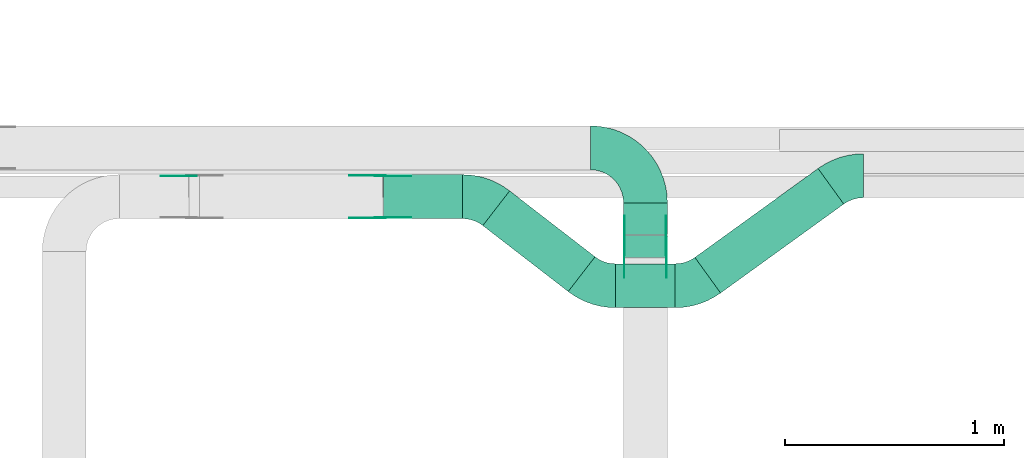
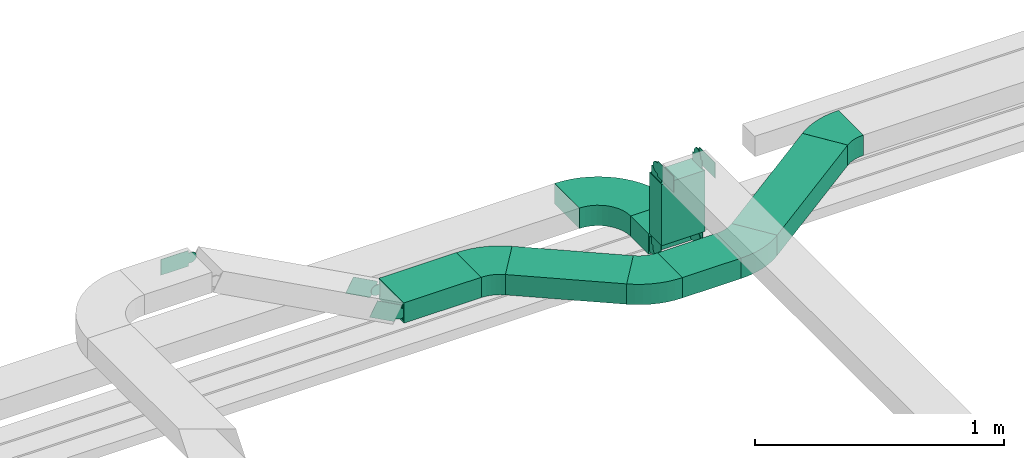
# One storey, part 5 of 25: 18 flow fittings, 6 flow segments.
"""IFC2X3 building model written with IfcOpenShell, lengths in millimetres."""

from ifc_helpers import new_model, entity, si_unit, converted_unit, derived_unit, direction, frame, frame_2d, origin, origin_2d_with_axis, place, context, subcontext, project, spatial, polyline, circle_curve, parameter, trimmed, segment, composite_curve, rectangle, outline, extrude, source, transform, mapped, material, type_object, type_shapes, element, save


model = new_model("IFC2X3")

# Units and contexts
model_context = context("Model", 3, precision=0.01, world=origin(), true_north=direction((6.12303176911189e-17, 1.0)))
body_context = subcontext(model_context, "Body", "Model", "MODEL_VIEW")
ifc_project = project(units=[si_unit("LENGTHUNIT", "METRE", prefix="MILLI"), si_unit("AREAUNIT", "SQUARE_METRE"), si_unit("VOLUMEUNIT", "CUBIC_METRE"), converted_unit("PLANEANGLEUNIT", "DEGREE", entity("IfcRatioMeasure", 0.0174532925199433), si_unit("PLANEANGLEUNIT", "RADIAN"), dimensions=[0, 0, 0, 0, 0, 0, 0]), si_unit("MASSUNIT", "GRAM", prefix="KILO"), derived_unit("MASSDENSITYUNIT", [(si_unit("MASSUNIT", "GRAM", prefix="KILO"), 1), (si_unit("LENGTHUNIT", "METRE"), -3)]), derived_unit("MOMENTOFINERTIAUNIT", [(si_unit("LENGTHUNIT", "METRE"), 4)]), si_unit("TIMEUNIT", "SECOND"), si_unit("FREQUENCYUNIT", "HERTZ"), si_unit("THERMODYNAMICTEMPERATUREUNIT", "DEGREE_CELSIUS"), derived_unit("THERMALTRANSMITTANCEUNIT", [(si_unit("MASSUNIT", "GRAM", prefix="KILO"), 1), (si_unit("THERMODYNAMICTEMPERATUREUNIT", "KELVIN"), -1), (si_unit("TIMEUNIT", "SECOND"), -3)]), derived_unit("VOLUMETRICFLOWRATEUNIT", [(si_unit("LENGTHUNIT", "METRE"), 3), (si_unit("TIMEUNIT", "SECOND"), -1)]), derived_unit("MASSFLOWRATEUNIT", [(si_unit("MASSUNIT", "GRAM", prefix="KILO"), 1), (si_unit("TIMEUNIT", "SECOND"), -1)]), derived_unit("ROTATIONALFREQUENCYUNIT", [(si_unit("TIMEUNIT", "SECOND"), -1)]), si_unit("ELECTRICCURRENTUNIT", "AMPERE"), si_unit("ELECTRICVOLTAGEUNIT", "VOLT"), si_unit("POWERUNIT", "WATT"), si_unit("FORCEUNIT", "NEWTON", prefix="KILO"), si_unit("ILLUMINANCEUNIT", "LUX"), si_unit("LUMINOUSFLUXUNIT", "LUMEN"), si_unit("LUMINOUSINTENSITYUNIT", "CANDELA"), derived_unit("USERDEFINED", [(si_unit("MASSUNIT", "GRAM", prefix="KILO"), -1), (si_unit("LENGTHUNIT", "METRE"), -2), (si_unit("TIMEUNIT", "SECOND"), 3), (si_unit("LUMINOUSFLUXUNIT", "LUMEN"), 1)]), derived_unit("LINEARVELOCITYUNIT", [(si_unit("LENGTHUNIT", "METRE"), 1), (si_unit("TIMEUNIT", "SECOND"), -1)]), si_unit("PRESSUREUNIT", "PASCAL"), derived_unit("USERDEFINED", [(si_unit("LENGTHUNIT", "METRE"), -2), (si_unit("MASSUNIT", "GRAM", prefix="KILO"), 1), (si_unit("TIMEUNIT", "SECOND"), -2)]), derived_unit("LINEARFORCEUNIT", [(si_unit("MASSUNIT", "GRAM", prefix="KILO"), 1), (si_unit("LENGTHUNIT", "METRE"), 1), (si_unit("TIMEUNIT", "SECOND"), -2), (si_unit("LENGTHUNIT", "METRE"), -1)]), derived_unit("PLANARFORCEUNIT", [(si_unit("MASSUNIT", "GRAM", prefix="KILO"), 1), (si_unit("LENGTHUNIT", "METRE"), 1), (si_unit("TIMEUNIT", "SECOND"), -2), (si_unit("LENGTHUNIT", "METRE"), -2)])], contexts=[model_context])

# Site, building, storey
site_placement = place(None, frame((0.0, -0.00077364408347762, 0.0)))
site = spatial("IfcSite", under=ifc_project, at=site_placement, CompositionType="ELEMENT")
building_placement = place(site_placement, origin())
building = spatial("IfcBuilding", under=site, at=building_placement, CompositionType="ELEMENT")
storey_placement = place(building_placement, frame((0.0, 0.0, 24000.0)))
storey = spatial("IfcBuildingStorey", under=building, at=storey_placement, CompositionType="ELEMENT", Elevation=24000.0)

# Flow segments
cable_carrier_segment_type = type_object("IfcCableCarrierSegmentType", PredefinedType="CABLETRAYSEGMENT")
flow_segment_1_placement = place(storey_placement, frame((22684.9807114228, 9729.94253623869, 2890.0)))
element("IfcFlowSegment", 1, at=flow_segment_1_placement, inside=storey, type_object=cable_carrier_segment_type, context=body_context, shape_type="SweptSolid", body=[
    extrude(rectangle(XDim=143.999999999998, YDim=199.999999999998, at=origin_2d_with_axis()), frame((100.0, 72.0, 0.0), z_axis=(0.0, 0.0, 1.0), x_axis=(0.0, -1.0, 0.0)), (0.0, 0.0, 1.0), 100.000000000003),
])
flow_segment_2_placement = place(storey_placement, frame((22684.9807114228, 9624.94253623869, 2995.0)))
element("IfcFlowSegment", 2, at=flow_segment_2_placement, inside=storey, type_object=cable_carrier_segment_type, context=body_context, shape_type="SweptSolid", body=[
    extrude(rectangle(XDim=199.999999999998, YDim=100.000000000001, at=origin_2d_with_axis()), frame((100.0, 50.0, 0.0)), (0.0, 0.0, 1.0), 299.999986293866),
])
flow_segment_3_placement = place(storey_placement, frame((21591.4331390634, 9802.6648899449, 2890.0)))
element("IfcFlowSegment", 3, at=flow_segment_3_placement, inside=storey, type_object=cable_carrier_segment_type, context=body_context, shape_type="SweptSolid", body=[
    extrude(rectangle(XDim=359.111266245777, YDim=199.999999999998, at=origin_2d_with_axis()), frame((179.555633122888, 100.0, 0.0), z_axis=(0.0, 0.0, 1.0), x_axis=(-1.0, 0.0, 0.0)), (0.0, 0.0, 1.0), 100.000000000003),
])
flow_segment_4_placement = place(storey_placement, frame((22648.7585625683, 9396.68870052396, 2890.0)))
element("IfcFlowSegment", 4, at=flow_segment_4_placement, inside=storey, type_object=cable_carrier_segment_type, context=body_context, shape_type="SweptSolid", body=[
    extrude(rectangle(XDim=271.84445040066, YDim=200.0, at=frame_2d((0.0, 5.47117906535277e-13), x_axis=(1.0, 0.0))), frame((135.92222520033, 100.0, 0.0)), (0.0, 0.0, 1.0), 100.000000000003),
])
flow_segment_5_placement = place(storey_placement, frame((22044.0293540784, 9470.30772844404, 2890.0)))
element("IfcFlowSegment", 5, at=flow_segment_5_placement, inside=storey, type_object=cable_carrier_segment_type, context=body_context, shape_type="SweptSolid", body=[
    extrude(rectangle(XDim=491.512542620555, YDim=200.000000000002, at=origin_2d_with_axis()), frame((255.622129860332, 229.369066790387, 0.0), z_axis=(0.0, 0.0, 1.0), x_axis=(-0.791406463891307, 0.611290282035514, 0.0)), (0.0, 0.0, 1.0), 100.000000000003),
])
flow_segment_6_placement = place(storey_placement, frame((23010.2445644588, 9463.54885381026, 2890.0)))
element("IfcFlowSegment", 6, at=flow_segment_6_placement, inside=storey, type_object=cable_carrier_segment_type, context=body_context, shape_type="SweptSolid", body=[
    extrude(rectangle(XDim=692.157993245641, YDim=200.0, at=frame_2d((-2.1032064978499e-12, 8.31335000839317e-13), x_axis=(1.0, 0.0))), frame((339.100786744327, 283.707278363112, 0.0), z_axis=(0.0, 0.0, 1.0), x_axis=(0.810643960277806, 0.585539383530361, 0.0)), (0.0, 0.0, 1.0), 100.000000000003),
])

# Flow fittings
ifc_material_1 = material(Name="G")
cable_carrier_fitting_type_1 = type_object("IfcCableCarrierFittingType", PredefinedType="NOTDEFINED", material=ifc_material_1)
shared_shape_1 = source(origin(), body_context, "Body", "SweptSolid", [
    extrude(outline(composite_curve([segment(trimmed(circle_curve(frame_2d((-41.4651162790697, 0.0), x_axis=(1.0, 0.0)), 25.0), [parameter(90.0000000000007)], [parameter(270.0)], True, "PARAMETER"), True, "CONTINUOUS"), segment(polyline([(-41.4651162790697, -25.0), (-29.9651162790697, -25.0)]), True, "CONTINUOUS"), segment(polyline([(-29.9651162790697, -25.0), (-28.1046511627907, -38.5)]), True, "CONTINUOUS"), segment(polyline([(-28.1046511627907, -38.5), (99.5348837209303, -38.5)]), True, "CONTINUOUS"), segment(polyline([(99.5348837209303, -38.5), (99.5348837209303, 38.5)]), True, "CONTINUOUS"), segment(polyline([(99.5348837209303, 38.5), (-28.1046511627907, 38.5)]), True, "CONTINUOUS"), segment(polyline([(-28.1046511627907, 38.5), (-29.9651162790697, 25.0)]), True, "CONTINUOUS"), segment(polyline([(-29.9651162790697, 25.0), (-41.46511627907, 25.0)]), True, "CONTINUOUS")], self_intersect=False)), frame((41.4651162790697, 0.0, 0.0), z_axis=(0.0, 0.0, -1.0), x_axis=(1.0, 0.0, 0.0)), (0.0, 0.0, -1.0), 2.0),
])
type_shapes(cable_carrier_fitting_type_1, [shared_shape_1])
for number, where, z_axis, x_axis in (
    (7, (22880.440711433, 9674.94253623868, 3350.0), (1.0, 0.0, 0.0), (0.0, -1.0, -2.53817257434008e-07)),
    (8, (21576.8531130699, 9998.12488995506, 2940.0), (0.0, 1.0, 0.0), (-0.881037228424637, 0.0, 0.473046934383719)),
    (9, (22689.5207114127, 9674.94253623868, 2940.0), (-1.0, 0.0, 0.0), (0.0, 0.0, 1.0)),
):
    element("IfcFlowFitting", number, at=place(storey_placement, frame(where, z_axis=z_axis, x_axis=x_axis)), inside=storey, type_object=cable_carrier_fitting_type_1, material=ifc_material_1, context=body_context, shape_type="MappedRepresentation", body=[
        mapped(shared_shape_1, transform((0.0, 0.0, 0.0), scale=1.0)),
    ])
cable_carrier_fitting_type_2 = type_object("IfcCableCarrierFittingType", PredefinedType="NOTDEFINED", material=ifc_material_1)
shared_shape_2 = source(origin(), body_context, "Body", "SweptSolid", [
    extrude(outline(composite_curve([segment(trimmed(circle_curve(frame_2d((-41.4651162790697, 0.0), x_axis=(1.0, 0.0)), 25.0), [parameter(90.0000000000007)], [parameter(270.0)], True, "PARAMETER"), True, "CONTINUOUS"), segment(polyline([(-41.4651162790697, -25.0), (-29.9651162790697, -25.0)]), True, "CONTINUOUS"), segment(polyline([(-29.9651162790697, -25.0), (-28.1046511627907, -38.5)]), True, "CONTINUOUS"), segment(polyline([(-28.1046511627907, -38.5), (99.5348837209303, -38.5)]), True, "CONTINUOUS"), segment(polyline([(99.5348837209303, -38.5), (99.5348837209303, 38.5)]), True, "CONTINUOUS"), segment(polyline([(99.5348837209303, 38.5), (-28.1046511627907, 38.5)]), True, "CONTINUOUS"), segment(polyline([(-28.1046511627907, 38.5), (-29.9651162790697, 25.0)]), True, "CONTINUOUS"), segment(polyline([(-29.9651162790697, 25.0), (-41.46511627907, 25.0)]), True, "CONTINUOUS")], self_intersect=False)), frame((41.4651162790697, 0.0, 0.0)), (0.0, 0.0, 1.0), 2.0),
])
type_shapes(cable_carrier_fitting_type_2, [shared_shape_2])
for number, where, z_axis, x_axis in (
    (10, (22689.5207114127, 9674.94253623868, 3350.0), (-1.0, 0.0, 0.0), (0.0, -1.0, -2.53817257434008e-07)),
    (11, (21576.8531130699, 9807.20488993474, 2940.0), (0.0, -1.0, 0.0), (-0.881037228424637, 0.0, 0.473046934383719)),
    (12, (22880.440711433, 9674.94253623868, 2940.0), (1.0, 0.0, 0.0), (0.0, 0.0, 1.0)),
):
    element("IfcFlowFitting", number, at=place(storey_placement, frame(where, z_axis=z_axis, x_axis=x_axis)), inside=storey, type_object=cable_carrier_fitting_type_2, material=ifc_material_1, context=body_context, shape_type="MappedRepresentation", body=[
        mapped(shared_shape_2, transform((0.0, 0.0, 0.0), scale=1.0)),
    ])
cable_carrier_fitting_type_3 = type_object("IfcCableCarrierFittingType", PredefinedType="NOTDEFINED", material=ifc_material_1)
shared_shape_3 = source(origin(), body_context, "Body", "SweptSolid", [
    extrude(outline(composite_curve([segment(trimmed(circle_curve(frame_2d((-41.4651162790697, 0.0), x_axis=(1.0, 0.0)), 25.0), [parameter(90.0000000000007)], [parameter(270.0)], True, "PARAMETER"), True, "CONTINUOUS"), segment(polyline([(-41.4651162790697, -25.0), (-29.9651162790697, -25.0)]), True, "CONTINUOUS"), segment(polyline([(-29.9651162790697, -25.0), (-28.1046511627907, -38.5)]), True, "CONTINUOUS"), segment(polyline([(-28.1046511627907, -38.5), (99.5348837209303, -38.5)]), True, "CONTINUOUS"), segment(polyline([(99.5348837209303, -38.5), (99.5348837209303, 38.5)]), True, "CONTINUOUS"), segment(polyline([(99.5348837209303, 38.5), (-28.1046511627907, 38.5)]), True, "CONTINUOUS"), segment(polyline([(-28.1046511627907, 38.5), (-29.9651162790697, 25.0)]), True, "CONTINUOUS"), segment(polyline([(-29.9651162790697, 25.0), (-41.46511627907, 25.0)]), True, "CONTINUOUS")], self_intersect=False)), frame((41.4651162790697, 0.0, 0.0), z_axis=(0.0, 0.0, -1.0), x_axis=(1.0, 0.0, 0.0)), (0.0, 0.0, -1.0), 2.0),
])
type_shapes(cable_carrier_fitting_type_3, [shared_shape_3])
for number, where, z_axis, x_axis in (
    (13, (22691.5207114127, 9674.9425362387, 3350.0), (-1.0, 0.0, 0.0), (0.0, 0.0, -1.0)),
    (14, (21576.8531130699, 9809.20488993474, 2940.0), (0.0, -1.0, 0.0), (1.0, 0.0, 0.0)),
    (15, (22878.440711433, 9674.94253623869, 2940.0), (1.0, 0.0, 0.0), (0.0, 1.0, 0.0)),
):
    element("IfcFlowFitting", number, at=place(storey_placement, frame(where, z_axis=z_axis, x_axis=x_axis)), inside=storey, type_object=cable_carrier_fitting_type_3, material=ifc_material_1, context=body_context, shape_type="MappedRepresentation", body=[
        mapped(shared_shape_3, transform((0.0, 0.0, 0.0), scale=1.0)),
    ])
cable_carrier_fitting_type_4 = type_object("IfcCableCarrierFittingType", PredefinedType="NOTDEFINED", material=ifc_material_1)
shared_shape_4 = source(origin(), body_context, "Body", "SweptSolid", [
    extrude(outline(composite_curve([segment(trimmed(circle_curve(frame_2d((-41.4651162790697, 0.0), x_axis=(1.0, 0.0)), 25.0), [parameter(90.0000000000007)], [parameter(270.0)], True, "PARAMETER"), True, "CONTINUOUS"), segment(polyline([(-41.4651162790697, -25.0), (-29.9651162790697, -25.0)]), True, "CONTINUOUS"), segment(polyline([(-29.9651162790697, -25.0), (-28.1046511627907, -38.5)]), True, "CONTINUOUS"), segment(polyline([(-28.1046511627907, -38.5), (99.5348837209303, -38.5)]), True, "CONTINUOUS"), segment(polyline([(99.5348837209303, -38.5), (99.5348837209303, 38.5)]), True, "CONTINUOUS"), segment(polyline([(99.5348837209303, 38.5), (-28.1046511627907, 38.5)]), True, "CONTINUOUS"), segment(polyline([(-28.1046511627907, 38.5), (-29.9651162790697, 25.0)]), True, "CONTINUOUS"), segment(polyline([(-29.9651162790697, 25.0), (-41.46511627907, 25.0)]), True, "CONTINUOUS")], self_intersect=False)), frame((41.4651162790697, 0.0, 0.0)), (0.0, 0.0, 1.0), 2.0),
])
type_shapes(cable_carrier_fitting_type_4, [shared_shape_4])
for number, where, z_axis, x_axis in (
    (16, (22878.440711433, 9674.9425362387, 3350.0), (1.0, 0.0, 0.0), (0.0, 0.0, -1.0)),
    (17, (20716.8706665486, 9996.12488995506, 3401.74219071096), (0.0, 1.0, 0.0), (-1.0, 0.0, 0.0)),
    (18, (21576.8531130699, 9996.12488995505, 2940.0), (0.0, 1.0, 0.0), (1.0, 0.0, 0.0)),
    (19, (22691.5207114127, 9674.94253623869, 2940.0), (-1.0, 0.0, 0.0), (0.0, 1.0, 0.0)),
):
    element("IfcFlowFitting", number, at=place(storey_placement, frame(where, z_axis=z_axis, x_axis=x_axis)), inside=storey, type_object=cable_carrier_fitting_type_4, material=ifc_material_1, context=body_context, shape_type="MappedRepresentation", body=[
        mapped(shared_shape_4, transform((0.0, 0.0, 0.0), scale=1.0)),
    ])
ifc_material_2 = material()
cable_carrier_fitting_type_5 = type_object("IfcCableCarrierFittingType", Name="470_DKC_S5_Variable Angle Elbow 0-45:-", PredefinedType="NOTDEFINED", material=ifc_material_2)
shared_shape_5 = source(origin(), body_context, "Body", "SweptSolid", [
    extrude(outline(composite_curve([segment(polyline([(-125.750000000001, -225.25), (-124.749999999999, -225.25)]), True, "CONTINUOUS"), segment(trimmed(circle_curve(frame_2d((-124.75, 124.75), x_axis=(0.0, -1.0)), 350.0), [parameter(0.0)], [parameter(90.0000000000001)], True, "PARAMETER"), True, "CONTINUOUS"), segment(polyline([(225.25, 124.75), (225.25, 125.749999999999)]), True, "CONTINUOUS"), segment(polyline([(225.25, 125.749999999999), (25.25, 125.750000000001)]), True, "CONTINUOUS"), segment(polyline([(25.25, 125.750000000001), (25.25, 124.75)]), True, "CONTINUOUS"), segment(trimmed(circle_curve(frame_2d((-124.75, 124.75), x_axis=(0.0, -1.0)), 150.0), [parameter(0.0)], [parameter(90.0000000000001)], True, "PARAMETER"), False, "CONTINUOUS"), segment(polyline([(-124.749999999999, -25.2500000000003), (-125.750000000001, -25.2500000000003)]), True, "CONTINUOUS"), segment(polyline([(-125.750000000001, -25.2500000000003), (-125.750000000001, -225.25)]), True, "CONTINUOUS")], self_intersect=False)), frame((-125.249999999991, 125.249999999992, -50.0)), (0.0, 0.0, 1.0), 100.0),
])
type_shapes(cable_carrier_fitting_type_5, [shared_shape_5])
flow_fitting_1_placement = place(storey_placement, frame((22784.9807114228, 10124.9425362387, 2940.0), z_axis=(0.0, 0.0, 1.0), x_axis=(0.0, 1.0, 0.0)))
element("IfcFlowFitting", 20, at=flow_fitting_1_placement, inside=storey, type_object=cable_carrier_fitting_type_5, material=ifc_material_2, Name="470_DKC_S5_Variable Angle Elbow 0-45:-", ObjectType="470_DKC_S5_Variable Angle Elbow 0-45:-", context=body_context, shape_type="MappedRepresentation", body=[
    mapped(shared_shape_5, transform((0.0, 0.0, 0.0), scale=1.0)),
])
cable_carrier_fitting_type_6 = type_object("IfcCableCarrierFittingType", Name="470_DKC_S5_Variable Angle Elbow 0-45:-", PredefinedType="NOTDEFINED", material=ifc_material_2)
shared_shape_6 = source(origin(), body_context, "Body", "SweptSolid", [
    extrude(outline(composite_curve([segment(polyline([(-77.3591368704102, -126.227014584093), (-76.3591368704089, -126.227014584093)]), True, "CONTINUOUS"), segment(trimmed(circle_curve(frame_2d((-76.3591368704093, 223.772985415906), x_axis=(0.0, -1.0)), 350.0), [parameter(0.0)], [parameter(37.6828573416333)], True, "PARAMETER"), True, "CONTINUOUS"), segment(polyline([(137.592461842013, -53.2192769460566), (138.383868305904, -52.6079866640211)]), True, "CONTINUOUS"), segment(polyline([(138.383868305904, -52.6079866640211), (16.1258118988058, 105.673306114243)]), True, "CONTINUOUS"), segment(polyline([(16.1258118988058, 105.673306114243), (15.3344054349144, 105.062015832208)]), True, "CONTINUOUS"), segment(trimmed(circle_curve(frame_2d((-76.3591368704093, 223.772985415906), x_axis=(0.0, -1.0)), 150.0), [parameter(0.0)], [parameter(37.6828573416333)], True, "PARAMETER"), False, "CONTINUOUS"), segment(polyline([(-76.3591368704089, 73.7729854159064), (-77.3591368704102, 73.7729854159064)]), True, "CONTINUOUS"), segment(polyline([(-77.3591368704102, 73.7729854159064), (-77.3591368704102, -126.227014584093)]), True, "CONTINUOUS")], self_intersect=False)), frame((-8.9495708903586, 26.2270145840854, -50.0)), (0.0, 0.0, 1.0), 100.0),
])
type_shapes(cable_carrier_fitting_type_6, [shared_shape_6])
for number, where, z_axis, x_axis, name in (
    (21, (22562.4498548075, 9496.68870052399, 2940.0), (0.0, 0.0, 1.0), (0.791406463891316, -0.611290282035502, 0.0), "470_DKC_S5_Variable Angle Elbow 0-45:-"),
    (22, (22036.85311307, 9902.66488994488, 2940.0), (0.0, 0.0, 1.0), (-0.791406463891307, 0.611290282035514, 0.0), "470_DKC_S5_Variable Angle Elbow 0-45:-"),
):
    element("IfcFlowFitting", number, at=place(storey_placement, frame(where, z_axis=z_axis, x_axis=x_axis)), inside=storey, type_object=cable_carrier_fitting_type_6, material=ifc_material_2, Name=name, ObjectType="470_DKC_S5_Variable Angle Elbow 0-45:-", context=body_context, shape_type="MappedRepresentation", body=[
        mapped(shared_shape_6, transform((0.0, 0.0, 0.0), scale=1.0)),
    ])
cable_carrier_fitting_type_7 = type_object("IfcCableCarrierFittingType", Name="470_DKC_S5_Variable Angle Elbow 0-45:-", PredefinedType="NOTDEFINED", material=ifc_material_2)
shared_shape_7 = source(origin(), body_context, "Body", "SweptSolid", [
    extrude(outline(composite_curve([segment(polyline([(-74.1450839313615, -123.815889811154), (-73.1450839313603, -123.815889811154)]), True, "CONTINUOUS"), segment(trimmed(circle_curve(frame_2d((-73.1450839313607, 226.184110188846), x_axis=(0.0, -1.0)), 350.0), [parameter(0.0)], [parameter(35.8411041291456)], True, "PARAMETER"), True, "CONTINUOUS"), segment(polyline([(131.793700304255, -57.5412759083939), (132.604344264533, -56.9557365248637)]), True, "CONTINUOUS"), segment(polyline([(132.604344264532, -56.9557365248637), (15.4964675584667, 105.173055530702)]), True, "CONTINUOUS"), segment(polyline([(15.4964675584667, 105.173055530702), (14.6858235981888, 104.587516147172)]), True, "CONTINUOUS"), segment(trimmed(circle_curve(frame_2d((-73.1450839313607, 226.184110188846), x_axis=(0.0, -1.0)), 150.0), [parameter(0.0)], [parameter(35.8411041291456)], True, "PARAMETER"), False, "CONTINUOUS"), segment(polyline([(-73.1450839313603, 76.1841101888458), (-74.1450839313615, 76.1841101888458)]), True, "CONTINUOUS"), segment(polyline([(-74.1450839313615, 76.1841101888458), (-74.1450839313615, -123.815889811154)]), True, "CONTINUOUS")], self_intersect=False)), frame((-7.70175790722108, 23.815889811146, -50.0)), (0.0, 0.0, 1.0), 100.0),
])
type_shapes(cable_carrier_fitting_type_7, [shared_shape_7])
flow_fitting_2_placement = place(storey_placement, frame((23002.4498548075, 9496.68870052398, 2940.0)))
element("IfcFlowFitting", 23, at=flow_fitting_2_placement, inside=storey, type_object=cable_carrier_fitting_type_7, material=ifc_material_2, Name="470_DKC_S5_Variable Angle Elbow 0-45:-", ObjectType="470_DKC_S5_Variable Angle Elbow 0-45:-", context=body_context, shape_type="MappedRepresentation", body=[
    mapped(shared_shape_7, transform((0.0, 0.0, 0.0), scale=1.0)),
])
flow_fitting_3_placement = place(storey_placement, frame((23696.2408475987, 9997.82356382276, 2940.0), z_axis=(0.0, 0.0, 1.0), x_axis=(-1.0, 0.0, 0.0)))
element("IfcFlowFitting", 24, at=flow_fitting_3_placement, inside=storey, type_object=cable_carrier_fitting_type_7, material=ifc_material_2, Name="470_DKC_S5_Variable Angle Elbow 0-45:-", ObjectType="470_DKC_S5_Variable Angle Elbow 0-45:-", context=body_context, shape_type="MappedRepresentation", body=[
    mapped(shared_shape_7, transform((0.0, 0.0, 0.0), scale=1.0)),
])

save(model, "model.ifc")
